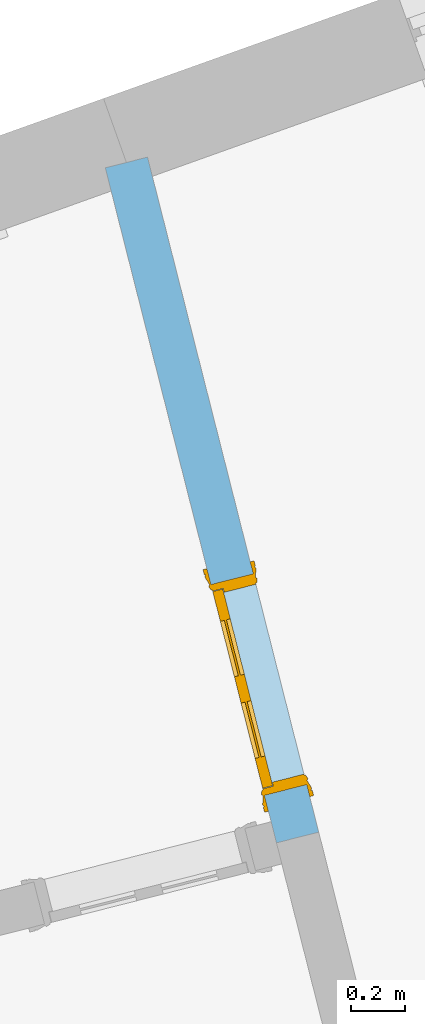
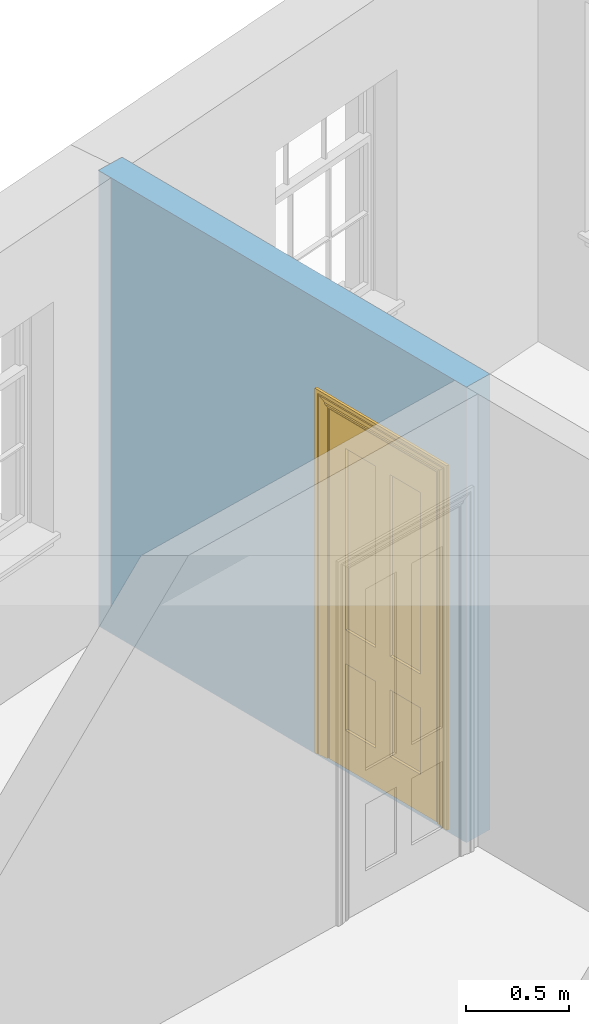
# One storey, part 13 of 15: 1 door, 1 opening, plus 1 element that does not belong to this part.
"""IFC2X3 building model written with IfcOpenShell, lengths in metres."""

from ifc_helpers import new_model, si_unit, frame, origin, place, context, subcontext, project, spatial, polyline, outline, extrude, faceted_brep, material, layer, layer_set, layer_usage, element, fill, save


model = new_model("IFC2X3")

# Units and contexts
model_context = context("Model", 3, world=origin())
body_context = subcontext(model_context, "Body", "Model", "MODEL_VIEW")
ifc_project = project(units=[si_unit("PLANEANGLEUNIT", "RADIAN"), si_unit("MASSUNIT", "GRAM", prefix="KILO"), si_unit("FORCEUNIT", "NEWTON", prefix="KILO"), si_unit("LENGTHUNIT", "METRE")], contexts=[model_context])

# Site, building, storey
site_placement = place(None, origin())
site = spatial("IfcSite", under=ifc_project, at=site_placement, CompositionType="ELEMENT")
building_placement = place(None, origin())
building = spatial("IfcBuilding", under=site, at=building_placement, Name="Building plot-13", CompositionType="ELEMENT")
storey_placement = place(None, frame((0.0, 0.0, 4.0)))
storey = spatial("IfcBuildingStorey", under=building, at=storey_placement, Name="Floor 0", CompositionType="ELEMENT", Elevation=4.0)

# Wall, opening, door
ifc_material = material(Name="Masonry")
ifc_layer = layer(ifc_material, 0.16, ventilated=False)
ifc_layer_set = layer_set([ifc_layer], Name="My Wall")
ifc_layer_usage = layer_usage(ifc_layer_set, "AXIS2", "NEGATIVE", 0.08)
wall_placement = place(storey_placement, origin())
wall = element("IfcWallStandardCase", 1, at=wall_placement, inside=storey, material=ifc_layer_usage, Name="interior", context=body_context, shape_type="SweptSolid", body=[
    extrude(outline(polyline([(76.2900472106932, 48.6394233762995), (76.4451367485746, 48.6787582875071), (75.8157454371402, 51.1603199496553), (75.6606558992588, 51.1209850384477), (76.2900472106932, 48.6394233762995)])), origin(), (0.0, 0.0, 1.0), 2.7),
])
opening_placement = place(storey_placement, frame((0.0, 0.0, 0.0199999999999996)))
opening = element("IfcOpeningElement", 2, at=opening_placement, cuts=wall, Name="Opening", ObjectType="Opening", context=body_context, shape_type="SweptSolid", body=[
    extrude(outline(polyline([(76.400884973466, 48.8532340176238), (76.2042104174276, 49.6286817070311), (76.0491208795462, 49.5893467958234), (76.2457954355845, 48.8138991064161), (76.400884973466, 48.8532340176238)])), origin(), (0.0, 0.0, 1.0), 2.1),
])
door_placement = place(storey_placement, frame((76.3233402045253, 48.8335665620199, 0.0199999999999996), z_axis=(0.0, 0.0, 1.0), x_axis=(-0.196674556038374, 0.775447689407294, 0.0)))
door = element("IfcDoor", 3, at=door_placement, inside=storey, Name="living inside door", OverallHeight=2.1, OverallWidth=0.8, context=body_context, shape_type="Brep", held_by="IfcProductRepresentation", body=[
    faceted_brep([(0.773, 0.08, 1.895), (0.66, 0.08, 1.895), (0.66, 0.08, 2.073), (0.773, 0.08, 2.073), (0.773, 0.08, 0.82), (0.66, 0.08, 0.82), (0.45, 0.08, 1.895), (0.45, 0.08, 2.073), (0.773, 0.08, 0.62), (0.66, 0.08, 0.62), (0.66, 0.065, 0.82), (0.66, 0.065, 1.895), (0.45, 0.065, 1.895), (0.35, 0.08, 1.895), (0.35, 0.08, 2.073), (0.773, 0.08, 0.225), (0.66, 0.08, 0.225), (0.45, 0.08, 0.62), (0.45, 0.08, 0.82), (0.45, 0.065, 0.82), (0.35, 0.08, 0.82), (0.14, 0.08, 2.073), (0.14, 0.08, 1.895), (0.773, 0.08, 0.0), (0.66, 0.08, 0.0), (0.66, 0.065, 0.225), (0.66, 0.065, 0.62), (0.45, 0.065, 0.62), (0.35, 0.08, 0.62), (0.35, 0.065, 0.82), (0.35, 0.065, 1.895), (0.14, 0.065, 1.895), (0.027, 0.08, 2.073), (0.027, 0.08, 1.895), (0.773, 0.042, 0.0), (0.66, 0.042, 0.0), (0.45, 0.08, 0.0), (0.45, 0.08, 0.225), (0.45, 0.065, 0.225), (0.35, 0.08, 0.225), (0.14, 0.08, 0.82), (0.14, 0.08, 0.62), (0.14, 0.065, 0.82), (0.027, 0.08, 0.82), (0.773, 0.042, 0.225), (0.66, 0.042, 0.225), (0.45, 0.042, 0.0), (0.35, 0.08, 0.0), (0.35, 0.065, 0.225), (0.35, 0.065, 0.62), (0.14, 0.065, 0.62), (0.027, 0.08, 0.62), (0.773, 0.042, 0.62), (0.66, 0.042, 0.62), (0.45, 0.042, 0.225), (0.35, 0.042, 0.0), (0.14, 0.08, 0.225), (0.14, 0.08, 0.0), (0.14, 0.065, 0.225), (0.027, 0.08, 0.225), (0.773, 0.042, 0.82), (0.66, 0.042, 0.82), (0.66, 0.057, 0.62), (0.66, 0.057, 0.225), (0.45, 0.057, 0.225), (0.35, 0.042, 0.225), (0.14, 0.042, 0.0), (0.027, 0.08, 0.0), (0.773, 0.042, 1.895), (0.66, 0.042, 1.895), (0.45, 0.042, 0.62), (0.45, 0.042, 0.82), (0.45, 0.057, 0.62), (0.35, 0.042, 0.62), (0.14, 0.042, 0.225), (0.027, 0.042, 0.0), (0.773, 0.042, 2.073), (0.66, 0.042, 2.073), (0.66, 0.057, 1.895), (0.66, 0.057, 0.82), (0.45, 0.057, 0.82), (0.35, 0.042, 0.82), (0.35, 0.057, 0.62), (0.35, 0.057, 0.225), (0.14, 0.057, 0.225), (0.027, 0.042, 0.225), (0.45, 0.042, 1.895), (0.45, 0.042, 2.073), (0.45, 0.057, 1.895), (0.35, 0.042, 1.895), (0.14, 0.042, 0.82), (0.14, 0.042, 0.62), (0.14, 0.057, 0.62), (0.027, 0.042, 0.62), (0.35, 0.042, 2.073), (0.35, 0.057, 1.895), (0.35, 0.057, 0.82), (0.14, 0.057, 0.82), (0.027, 0.042, 0.82), (0.14, 0.042, 2.073), (0.14, 0.042, 1.895), (0.14, 0.057, 1.895), (0.027, 0.042, 1.895), (0.027, 0.042, 2.073), (0.02, 0.085, 0.0), (0.005, 0.09, 0.0), (0.005, 0.09, 2.095), (0.02, 0.085, 2.08), (0.02, 0.08, 0.0), (0.0, 0.085, 0.0), (0.0, 0.085, 2.1), (0.795, 0.09, 2.095), (0.78, 0.085, 2.08), (0.02, 0.08, 2.08), (0.0, 0.08, 0.0), (-0.032, 0.095, 0.0), (-0.032, 0.095, 2.132), (0.8, 0.085, 2.1), (0.795, 0.09, 0.0), (0.78, 0.085, 0.0), (0.78, 0.08, 2.08), (0.04, 0.04, 0.0), (0.025, 0.04, 0.0), (0.025, 0.04, 2.075), (0.04, 0.04, 2.06), (-0.04, 0.09, 0.0), (-0.04, 0.09, 2.14), (0.832, 0.095, 2.132), (0.8, 0.085, 0.0), (0.78, 0.08, 0.0), (0.8, 0.08, 0.0), (0.86, 0.08, 0.0), (0.86, 0.08, 2.16), (0.8, 0.08, 2.1), (-0.06, 0.08, 2.16), (0.0, 0.08, 2.1), (-0.06, 0.08, 0.0), (-0.04, 0.095, 0.0), (-0.04, 0.095, 2.14), (0.84, 0.09, 2.14), (0.832, 0.095, 0.0), (0.84, 0.09, 0.0), (0.86, 0.095, 0.0), (0.86, 0.095, 2.16), (-0.06, 0.095, 2.16), (-0.06, 0.095, 0.0), (0.84, 0.095, 0.0), (0.84, 0.095, 2.14), (-0.025, -0.095, 0.0), (-0.025, -0.09, 0.0), (-0.025, -0.09, 2.125), (-0.025, -0.095, 2.125), (-0.017, -0.095, 0.0), (-0.017, -0.095, 2.117), (0.825, -0.09, 2.125), (0.825, -0.095, 2.125), (0.825, -0.095, 0.0), (0.845, -0.095, 0.0), (-0.045, -0.095, 2.145), (-0.045, -0.095, 0.0), (0.845, -0.095, 2.145), (0.015, -0.085, 0.0), (0.015, -0.085, 2.085), (0.817, -0.095, 2.117), (0.825, -0.09, 0.0), (0.845, -0.08, 0.0), (0.845, -0.08, 2.145), (-0.045, -0.08, 2.145), (-0.045, -0.08, 0.0), (0.02, -0.09, 0.0), (0.02, -0.09, 2.08), (0.785, -0.085, 2.085), (0.817, -0.095, 0.0), (0.8, -0.08, 0.0), (0.8, -0.08, 2.1), (0.0, -0.08, 2.1), (0.0, -0.08, 0.0), (0.035, -0.085, 0.0), (0.035, -0.085, 2.065), (0.78, -0.09, 2.08), (0.785, -0.085, 0.0), (0.775, 0.04, 2.075), (0.76, 0.04, 2.06), (0.035, -0.08, 2.065), (0.035, -0.08, 0.0), (0.765, -0.085, 2.065), (0.78, -0.09, 0.0), (0.765, -0.08, 0.0), (0.765, -0.08, 2.065), (0.765, -0.085, 0.0), (0.04, -0.08, 2.06), (0.04, -0.08, 0.0), (0.76, -0.08, 2.06), (0.76, -0.08, 0.0), (0.76, 0.04, 0.0), (0.775, 0.04, 0.0), (0.025, 0.08, 0.0), (0.025, 0.08, 2.075), (0.775, 0.08, 0.0), (0.775, 0.08, 2.075)], [[[0, 1, 2, 3]], [[1, 0, 4, 5]], [[1, 6, 7, 2]], [[8, 9, 5, 4]], [[1, 5, 10, 11]], [[6, 1, 11, 12]], [[6, 13, 14, 7]], [[15, 16, 9, 8]], [[9, 17, 18, 5]], [[5, 18, 19, 10]], [[10, 19, 12, 11]], [[18, 6, 12, 19]], [[18, 20, 13, 6]], [[21, 14, 13, 22]], [[23, 24, 16, 15]], [[9, 16, 25, 26]], [[17, 9, 26, 27]], [[17, 28, 20, 18]], [[13, 20, 29, 30]], [[22, 13, 30, 31]], [[32, 21, 22, 33]], [[34, 35, 24, 23]], [[24, 36, 37, 16]], [[16, 37, 38, 25]], [[25, 38, 27, 26]], [[37, 17, 27, 38]], [[37, 39, 28, 17]], [[40, 20, 28, 41]], [[20, 40, 42, 29]], [[31, 30, 29, 42]], [[40, 22, 31, 42]], [[33, 22, 40, 43]], [[35, 34, 44, 45]], [[35, 46, 36, 24]], [[36, 47, 39, 37]], [[28, 39, 48, 49]], [[41, 28, 49, 50]], [[43, 40, 41, 51]], [[45, 44, 52, 53]], [[46, 35, 45, 54]], [[46, 55, 47, 36]], [[56, 39, 47, 57]], [[39, 56, 58, 48]], [[50, 49, 48, 58]], [[56, 41, 50, 58]], [[51, 41, 56, 59]], [[53, 52, 60, 61]], [[45, 53, 62, 63]], [[54, 45, 63, 64]], [[55, 46, 54, 65]], [[55, 66, 57, 47]], [[59, 56, 57, 67]], [[61, 60, 68, 69]], [[70, 53, 61, 71]], [[53, 70, 72, 62]], [[72, 64, 63, 62]], [[70, 54, 64, 72]], [[65, 54, 70, 73]], [[65, 74, 66, 55]], [[67, 57, 66, 75]], [[69, 68, 76, 77]], [[61, 69, 78, 79]], [[71, 61, 79, 80]], [[73, 70, 71, 81]], [[65, 73, 82, 83]], [[74, 65, 83, 84]], [[74, 85, 75, 66]], [[86, 69, 77, 87]], [[69, 86, 88, 78]], [[88, 80, 79, 78]], [[86, 71, 80, 88]], [[81, 71, 86, 89]], [[73, 81, 90, 91]], [[73, 91, 92, 82]], [[83, 82, 92, 84]], [[91, 74, 84, 92]], [[91, 93, 85, 74]], [[89, 86, 87, 94]], [[81, 89, 95, 96]], [[90, 81, 96, 97]], [[90, 98, 93, 91]], [[94, 99, 100, 89]], [[89, 100, 101, 95]], [[101, 97, 96, 95]], [[100, 90, 97, 101]], [[100, 102, 98, 90]], [[99, 103, 102, 100]], [[32, 103, 99, 21]], [[102, 103, 32, 33]], [[98, 102, 33, 43]], [[21, 99, 94, 14]], [[94, 87, 7, 14]], [[7, 87, 77, 2]], [[76, 3, 2, 77]], [[43, 51, 93, 98]], [[51, 59, 85, 93]], [[67, 75, 85, 59]], [[34, 23, 15, 44]], [[44, 15, 8, 52]], [[52, 8, 4, 60]], [[0, 68, 60, 4]], [[0, 3, 76, 68]], [[104, 105, 106, 107]], [[104, 108, 109, 105]], [[105, 109, 110, 106]], [[107, 106, 111, 112]], [[107, 113, 108, 104]], [[114, 109, 108]], [[109, 115, 116, 110]], [[106, 110, 117, 111]], [[112, 111, 118, 119]], [[113, 107, 112, 120]], [[121, 122, 123, 124]], [[115, 109, 114, 125]], [[115, 125, 126, 116]], [[110, 116, 127, 117]], [[111, 117, 128, 118]], [[118, 128, 129, 119]], [[120, 112, 119, 129]], [[130, 129, 128]], [[130, 131, 132, 133]], [[133, 132, 134, 135]], [[135, 134, 136, 114]], [[136, 125, 114]], [[125, 137, 138, 126]], [[116, 126, 139, 127]], [[117, 127, 140, 128]], [[141, 130, 128, 140]], [[131, 130, 141]], [[131, 142, 143, 132]], [[132, 143, 144, 134]], [[134, 144, 145, 136]], [[137, 125, 136, 145]], [[143, 142, 146]], [[143, 146, 147]], [[137, 145, 144]], [[143, 147, 138]], [[138, 137, 144]], [[143, 138, 144]], [[126, 138, 147, 139]], [[127, 139, 141, 140]], [[142, 131, 141, 146]], [[139, 147, 146, 141]], [[148, 149, 150, 151]], [[149, 152, 153, 150]], [[151, 150, 154, 155]], [[155, 156, 157]], [[158, 159, 148]], [[158, 148, 151]], [[155, 157, 160]], [[158, 151, 155]], [[155, 160, 158]], [[152, 161, 162, 153]], [[150, 153, 163, 154]], [[155, 154, 164, 156]], [[156, 164, 165, 157]], [[157, 165, 166, 160]], [[160, 166, 167, 158]], [[158, 167, 168, 159]], [[161, 169, 170, 162]], [[153, 162, 171, 163]], [[154, 163, 172, 164]], [[165, 164, 173]], [[165, 173, 174, 166]], [[166, 174, 175, 167]], [[167, 175, 176, 168]], [[169, 177, 178, 170]], [[162, 170, 179, 171]], [[163, 171, 180, 172]], [[172, 180, 173, 164]], [[124, 123, 181, 182]], [[183, 178, 177, 184]], [[170, 178, 185, 179]], [[171, 179, 186, 180]], [[187, 173, 180]], [[185, 188, 187, 189]], [[188, 185, 178, 183]], [[179, 185, 189, 186]], [[189, 187, 180, 186]], [[190, 183, 184, 191]], [[192, 188, 183, 190]], [[191, 184, 122, 121]], [[124, 190, 191, 121]], [[193, 187, 188, 192]], [[182, 192, 190, 124]], [[184, 176, 122]], [[194, 195, 187, 193]], [[192, 182, 194, 193]], [[161, 176, 184]], [[114, 108, 122, 176]], [[173, 187, 195]], [[152, 149, 176, 161]], [[169, 161, 184, 177]], [[196, 122, 108]], [[176, 175, 135, 114]], [[173, 195, 129, 130]], [[176, 149, 168]], [[123, 122, 196, 197]], [[196, 108, 113, 197]], [[175, 174, 133, 135]], [[198, 129, 195]], [[133, 174, 173, 130]], [[159, 168, 149, 148]], [[181, 123, 197, 199]], [[197, 113, 120, 199]], [[199, 120, 129, 198]], [[195, 181, 199, 198]], [[195, 194, 182, 181]]]),
])
fill(opening, door)

save(model, "model.ifc")
